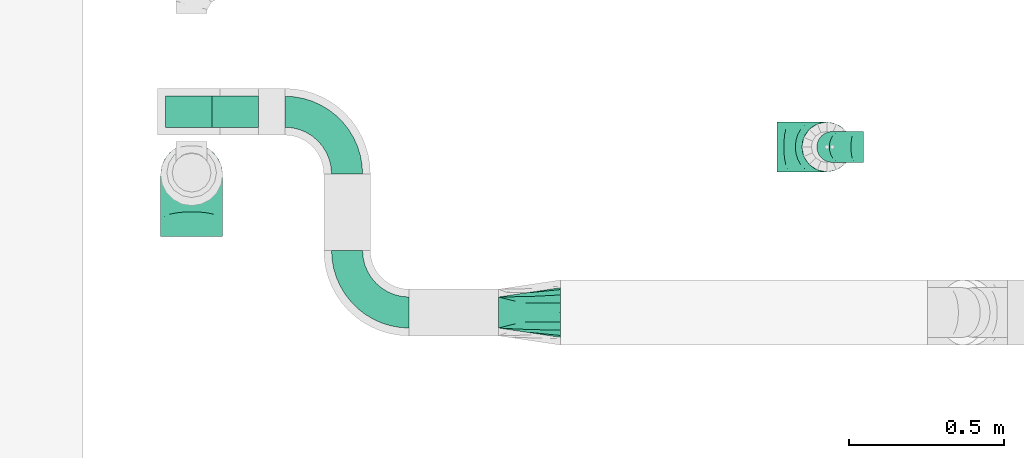
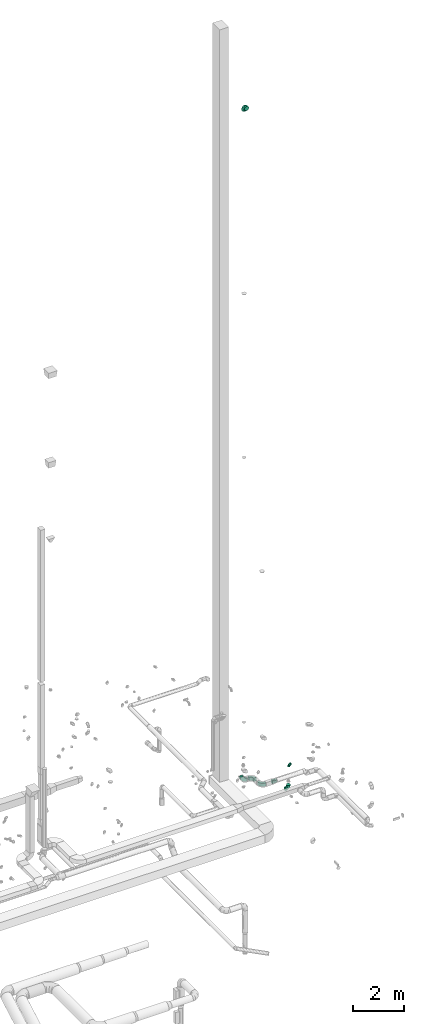
# One storey, part 74 of 97: 7 flow fittings.
"""IFC2X3 building model written with IfcOpenShell, lengths in millimetres."""

import ifcopenshell
import ifcopenshell.guid

model = None  # the IFC model being written
_history = None  # IfcOwnerHistory: only IFC2X3 demands one
_inside = {}  # id of a spatial element -> (the spatial element, [elements in it])
_under = {}  # id of a project, library or spatial element -> (it, [spatial elements below it])
_declared = {}  # id of a project -> (the project, [libraries it declares])
_typed = {}  # id of a type object -> (the type object, [elements of that type])
_made_of = {}  # id of a material, layer set ... -> (it, [elements and type objects made of it])


def new_model(schema):
    """Start an empty IFC model of exactly this schema.

    Asked for "IFC4X3", IfcOpenShell would pick the latest addendum, in which some entities
    have other attributes; the version numbers below select the first issue.
    IFC2X3 requires an IfcOwnerHistory on every rooted entity: one is made here for all.
    """
    global model, _history
    if schema == "IFC4X3":
        model = ifcopenshell.file(schema_version=(4, 3, 0, 0))
    else:
        model = ifcopenshell.file(schema=schema)
    _inside.clear()
    _under.clear()
    _declared.clear()
    _typed.clear()
    _made_of.clear()
    _history = None
    if model.schema == "IFC2X3":
        org = make("IfcOrganization", Name="unknown")
        user = make(
            "IfcPersonAndOrganization",
            ThePerson=make("IfcPerson", FamilyName="unknown"),
            TheOrganization=org,
        )
        app = make(
            "IfcApplication",
            ApplicationDeveloper=org,
            Version="unknown",
            ApplicationFullName="unknown",
            ApplicationIdentifier="unknown",
        )
        _history = make(
            "IfcOwnerHistory",
            OwningUser=user,
            OwningApplication=app,
            ChangeAction="ADDED",
            CreationDate=0,
        )
    return model


def make(cls, **values):
    """One entity of the class cls with the attributes given. An attribute that is None is left unset."""
    return model.create_entity(
        cls, **{name: value for name, value in values.items() if value is not None}
    )


def entity(cls, *values):
    """Any entity or typed value of the class cls, its attributes in the order of the schema. None: left unset."""
    e = model.create_entity(cls)
    for i, value in enumerate(values):
        if value is not None:
            e[i] = value
    return e


def rooted(cls, **values):
    """An entity with a GlobalId (a new one), such as an element, a storey or a relation."""
    return make(cls, GlobalId=ifcopenshell.guid.new(), OwnerHistory=_history, **values)


def si_unit(unit_type, name, prefix=None):
    """IfcSIUnit, for example si_unit("LENGTHUNIT", "METRE", prefix="MILLI")."""
    return make("IfcSIUnit", UnitType=unit_type, Prefix=prefix, Name=name)


def converted_unit(unit_type, name, factor, base, dimensions=None, offset=None):
    """IfcConversionBasedUnit, such as the inch: factor (a typed value) times the base unit."""
    return make(
        "IfcConversionBasedUnit"
        if offset is None
        else "IfcConversionBasedUnitWithOffset",
        ConversionOffset=offset,
        Dimensions=None
        if dimensions is None
        else entity("IfcDimensionalExponents", *dimensions),
        UnitType=unit_type,
        Name=name,
        ConversionFactor=make(
            "IfcMeasureWithUnit", ValueComponent=factor, UnitComponent=base
        ),
    )


def derived_unit(unit_type, elements):
    """IfcDerivedUnit: a product of units, each with its exponent."""
    return make(
        "IfcDerivedUnit",
        Elements=[
            make("IfcDerivedUnitElement", Unit=unit, Exponent=power)
            for unit, power in elements
        ],
        UnitType=unit_type,
    )


def assignment(units):
    """IfcUnitAssignment: the units of a project."""
    return None if units is None else make("IfcUnitAssignment", Units=units)


def point(xyz):
    """IfcCartesianPoint."""
    return None if xyz is None else make("IfcCartesianPoint", Coordinates=xyz)


def direction(xyz):
    """IfcDirection."""
    return None if xyz is None else make("IfcDirection", DirectionRatios=xyz)


def frame(location, z_axis=None, x_axis=None):
    """IfcAxis2Placement3D, a coordinate frame: its origin and axes. An axis left out is left unset."""
    return make(
        "IfcAxis2Placement3D",
        Location=point(location),
        Axis=direction(z_axis),
        RefDirection=direction(x_axis),
    )


def frame_2d(location, x_axis=None):
    """IfcAxis2Placement2D, a coordinate frame in the plane: its origin and x axis."""
    return make(
        "IfcAxis2Placement2D", Location=point(location), RefDirection=direction(x_axis)
    )


def origin():
    """The frame at (0, 0, 0) with its axes left unset."""
    return frame((0.0, 0.0, 0.0))


def place(relative_to, where):
    """IfcLocalPlacement: puts the frame where relative to a parent placement (None: the world)."""
    return make(
        "IfcLocalPlacement", PlacementRelTo=relative_to, RelativePlacement=where
    )


def context(
    kind, dimensions, precision=None, world=None, true_north=None, identifier=None
):
    """IfcGeometricRepresentationContext, for example the 3D "Model" context."""
    return make(
        "IfcGeometricRepresentationContext",
        ContextIdentifier=identifier,
        ContextType=kind,
        CoordinateSpaceDimension=dimensions,
        Precision=precision,
        WorldCoordinateSystem=world,
        TrueNorth=true_north,
    )


def subcontext(parent, identifier, kind, view, scale=None):
    """IfcGeometricRepresentationSubContext, for example "Body" below "Model"."""
    return make(
        "IfcGeometricRepresentationSubContext",
        ContextIdentifier=identifier,
        ContextType=kind,
        ParentContext=parent,
        TargetScale=scale,
        TargetView=view,
    )


def project(units=None, contexts=None):
    """IfcProject with its units and contexts."""
    return rooted(
        "IfcProject",
        Name="project",
        RepresentationContexts=contexts,
        UnitsInContext=assignment(units),
    )


def spatial(cls, under=None, at=None, **own):
    """A site, building, storey or space (cls), placed at a placement, below another one or the project."""
    s = rooted(cls, ObjectPlacement=at, **own)
    if under is not None:
        _under.setdefault(under.id(), (under, []))[1].append(s)
    return s


def polyline(points):
    """IfcPolyline through the points."""
    return make("IfcPolyline", Points=[point(p) for p in points])


def circle_curve(where, radius):
    """IfcCircle in the frame where."""
    return make("IfcCircle", Position=where, Radius=radius)


def parameter(value):
    """IfcParameterValue: where a trimmed curve begins or ends, as a parameter of its basis curve."""
    return model.create_entity("IfcParameterValue", value)


def trimmed(basis, trim1, trim2, sense, master):
    """IfcTrimmedCurve: the piece of a basis curve between two trims."""
    return make(
        "IfcTrimmedCurve",
        BasisCurve=basis,
        Trim1=trim1,
        Trim2=trim2,
        SenseAgreement=sense,
        MasterRepresentation=master,
    )


def segment(curve, same_sense, transition):
    """IfcCompositeCurveSegment."""
    return make(
        "IfcCompositeCurveSegment",
        Transition=transition,
        SameSense=same_sense,
        ParentCurve=curve,
    )


def composite_curve(segments, self_intersect=None):
    """IfcCompositeCurve: segments joined end to end."""
    return make("IfcCompositeCurve", Segments=segments, SelfIntersect=self_intersect)


def outline(outer, holes=None, kind="AREA"):
    """IfcArbitraryClosedProfileDef: a profile drawn as a closed curve; with holes, ...WithVoids."""
    if holes is None:
        return make("IfcArbitraryClosedProfileDef", ProfileType=kind, OuterCurve=outer)
    return make(
        "IfcArbitraryProfileDefWithVoids",
        ProfileType=kind,
        OuterCurve=outer,
        InnerCurves=holes,
    )


def extrude(swept, where, along, depth):
    """IfcExtrudedAreaSolid: the profile swept, set in the frame where, extruded along a direction by depth."""
    return make(
        "IfcExtrudedAreaSolid",
        SweptArea=swept,
        Position=where,
        ExtrudedDirection=direction(along),
        Depth=depth,
    )


def faces_of(points, faces, orient=None, outer=None):
    """IfcFace entities. A face is a list of loops; a loop is a list of indices into points, from 0.

    orient and outer hold one flag for each loop. By default every Orientation is true, the
    first loop of a face is its IfcFaceOuterBound and the others are IfcFaceBound.
    """
    made = []
    for i, loops in enumerate(faces):
        bounds = []
        for j, loop in enumerate(loops):
            is_outer = j == 0 if outer is None else outer[i][j]
            bounds.append(
                make(
                    "IfcFaceOuterBound" if is_outer else "IfcFaceBound",
                    Bound=make("IfcPolyLoop", Polygon=[points[k] for k in loop]),
                    Orientation=True if orient is None else orient[i][j],
                )
            )
        made.append(make("IfcFace", Bounds=bounds))
    return made


def faceted_brep(points, faces, orient=None, outer=None, voids=None):
    """IfcFacetedBrep: a solid bounded by flat faces; with voids (closed shells), ...WithVoids."""
    shared = [point(p) for p in points]
    hull = make("IfcClosedShell", CfsFaces=faces_of(shared, faces, orient, outer))
    if voids is None:
        return make("IfcFacetedBrep", Outer=hull)
    return make(
        "IfcFacetedBrepWithVoids",
        Outer=hull,
        Voids=[
            make(cls, CfsFaces=faces_of(shared, fs, o, b)) for cls, fs, o, b in voids
        ],
    )


def shape(context_of_items, identifier, shape_type, items):
    """IfcShapeRepresentation: the items that make up one representation, for example the "Body"."""
    return make(
        "IfcShapeRepresentation",
        ContextOfItems=context_of_items,
        RepresentationIdentifier=identifier,
        RepresentationType=shape_type,
        Items=items,
    )


def source(mapping_origin, context_of_items, identifier, shape_type, items):
    """IfcRepresentationMap: a shape defined once, which mapped items show again and again."""
    return make(
        "IfcRepresentationMap",
        MappingOrigin=mapping_origin,
        MappedRepresentation=shape(context_of_items, identifier, shape_type, items),
    )


def transform(
    local_origin,
    x_axis=None,
    y_axis=None,
    z_axis=None,
    scale=None,
    scale2=None,
    scale3=None,
    uniform=True,
):
    """IfcCartesianTransformationOperator3D, or its non-uniform kind. x_axis, y_axis, z_axis: its Axis1, 2, 3."""
    if uniform:
        return make(
            "IfcCartesianTransformationOperator3D",
            Axis1=direction(x_axis),
            Axis2=direction(y_axis),
            LocalOrigin=point(local_origin),
            Scale=scale,
            Axis3=direction(z_axis),
        )
    return make(
        "IfcCartesianTransformationOperator3DnonUniform",
        Axis1=direction(x_axis),
        Axis2=direction(y_axis),
        LocalOrigin=point(local_origin),
        Scale=scale,
        Axis3=direction(z_axis),
        Scale2=scale2,
        Scale3=scale3,
    )


def mapped(mapping_source, mapping_target):
    """IfcMappedItem: shows the shape of a source again, moved by a transform."""
    return make(
        "IfcMappedItem", MappingSource=mapping_source, MappingTarget=mapping_target
    )


def material(Name=None, Category=None):
    """IfcMaterial."""
    return make("IfcMaterial", Name=Name, Category=Category)


def made_of(thing, what):
    """Note that an element or type object is made of a material, layer set ...; save() writes the relation."""
    if what is not None:
        _made_of.setdefault(what.id(), (what, []))[1].append(thing)
    return thing


def type_object(cls, material=None, **own):
    """A type object (cls), such as IfcWallType, which elements share."""
    return made_of(rooted(cls, **own), material)


def type_shapes(of_type, sources):
    """Give a type object the sources (RepresentationMaps) that its elements show as mapped items."""
    of_type.RepresentationMaps = sources


def element(
    cls,
    number,
    at=None,
    inside=None,
    cuts=None,
    type_object=None,
    material=None,
    context=None,
    identifier="Body",
    shape_type=None,
    held_by="IfcProductDefinitionShape",
    body=None,
    shapes=None,
    **own,
):
    """One element of the class cls, such as IfcWall. Its Tag is "e" and its number.

    at: its placement. inside: the storey or other place that contains it. cuts: it is an
    opening in that element (IfcRelVoidsElement). A single representation is given by context,
    identifier, shape_type and body (its items); several are given by shapes. held_by: the class
    of the entity that holds the representations. save() writes the other relations.
    """
    e = rooted(cls, Tag="e%d" % number, ObjectPlacement=at, **own)
    if body is not None:
        shapes = [shape(context, identifier, shape_type, body)]
    if shapes is not None:
        e.Representation = make(held_by, Representations=shapes)
    if inside is not None:
        _inside.setdefault(inside.id(), (inside, []))[1].append(e)
    if cuts is not None:
        rooted(
            "IfcRelVoidsElement", RelatingBuildingElement=cuts, RelatedOpeningElement=e
        )
    if type_object is not None:
        _typed.setdefault(type_object.id(), (type_object, []))[1].append(e)
    return made_of(e, material)


def aggregate(whole, parts):
    """IfcRelAggregates: a whole, such as a stair, and the parts it consists of."""
    return rooted("IfcRelAggregates", RelatingObject=whole, RelatedObjects=parts)


def save(model, path):
    """Write the relations noted so far, then the file.

    IfcRelAggregates (storeys below a building ...), IfcRelContainedInSpatialStructure (elements
    in a storey), IfcRelDefinesByType, IfcRelAssociatesMaterial and IfcRelDeclares: one each for
    every whole, place, type object, material and project.
    """
    for whole, parts in _under.values():
        aggregate(whole, parts)
    for where, things in _inside.values():
        rooted(
            "IfcRelContainedInSpatialStructure",
            RelatedElements=things,
            RelatingStructure=where,
        )
    for kind, things in _typed.values():
        rooted("IfcRelDefinesByType", RelatedObjects=things, RelatingType=kind)
    for what, things in _made_of.values():
        rooted("IfcRelAssociatesMaterial", RelatedObjects=things, RelatingMaterial=what)
    for by, libraries in _declared.values():
        rooted("IfcRelDeclares", RelatingContext=by, RelatedDefinitions=libraries)
    model.write(path)


model = new_model("IFC2X3")

# Units and contexts
model_context = context("Model", 3, precision=0.01, world=origin(), true_north=direction((6.12303176911189e-17, 1.0)))
body_context = subcontext(model_context, "Body", "Model", "MODEL_VIEW")
ifc_project = project(units=[si_unit("LENGTHUNIT", "METRE", prefix="MILLI"), si_unit("AREAUNIT", "SQUARE_METRE"), si_unit("VOLUMEUNIT", "CUBIC_METRE"), converted_unit("PLANEANGLEUNIT", "DEGREE", entity("IfcRatioMeasure", 0.0174532925199433), si_unit("PLANEANGLEUNIT", "RADIAN"), dimensions=[0, 0, 0, 0, 0, 0, 0]), si_unit("MASSUNIT", "GRAM", prefix="KILO"), derived_unit("MASSDENSITYUNIT", [(si_unit("MASSUNIT", "GRAM", prefix="KILO"), 1), (si_unit("LENGTHUNIT", "METRE"), -3)]), derived_unit("MOMENTOFINERTIAUNIT", [(si_unit("LENGTHUNIT", "METRE"), 4)]), si_unit("TIMEUNIT", "SECOND"), si_unit("FREQUENCYUNIT", "HERTZ"), si_unit("THERMODYNAMICTEMPERATUREUNIT", "DEGREE_CELSIUS"), derived_unit("THERMALTRANSMITTANCEUNIT", [(si_unit("MASSUNIT", "GRAM", prefix="KILO"), 1), (si_unit("THERMODYNAMICTEMPERATUREUNIT", "KELVIN"), -1), (si_unit("TIMEUNIT", "SECOND"), -3)]), derived_unit("VOLUMETRICFLOWRATEUNIT", [(si_unit("LENGTHUNIT", "METRE"), 3), (si_unit("TIMEUNIT", "SECOND"), -1)]), derived_unit("MASSFLOWRATEUNIT", [(si_unit("MASSUNIT", "GRAM", prefix="KILO"), 1), (si_unit("TIMEUNIT", "SECOND"), -1)]), derived_unit("ROTATIONALFREQUENCYUNIT", [(si_unit("TIMEUNIT", "SECOND"), -1)]), si_unit("ELECTRICCURRENTUNIT", "AMPERE"), si_unit("ELECTRICVOLTAGEUNIT", "VOLT"), si_unit("POWERUNIT", "WATT"), si_unit("FORCEUNIT", "NEWTON", prefix="KILO"), si_unit("ILLUMINANCEUNIT", "LUX"), si_unit("LUMINOUSFLUXUNIT", "LUMEN"), si_unit("LUMINOUSINTENSITYUNIT", "CANDELA"), derived_unit("USERDEFINED", [(si_unit("MASSUNIT", "GRAM", prefix="KILO"), -1), (si_unit("LENGTHUNIT", "METRE"), -2), (si_unit("TIMEUNIT", "SECOND"), 3), (si_unit("LUMINOUSFLUXUNIT", "LUMEN"), 1)]), derived_unit("LINEARVELOCITYUNIT", [(si_unit("LENGTHUNIT", "METRE"), 1), (si_unit("TIMEUNIT", "SECOND"), -1)]), si_unit("PRESSUREUNIT", "PASCAL"), derived_unit("USERDEFINED", [(si_unit("LENGTHUNIT", "METRE"), -2), (si_unit("MASSUNIT", "GRAM", prefix="KILO"), 1), (si_unit("TIMEUNIT", "SECOND"), -2)]), derived_unit("LINEARFORCEUNIT", [(si_unit("MASSUNIT", "GRAM", prefix="KILO"), 1), (si_unit("LENGTHUNIT", "METRE"), 1), (si_unit("TIMEUNIT", "SECOND"), -2), (si_unit("LENGTHUNIT", "METRE"), -1)]), derived_unit("PLANARFORCEUNIT", [(si_unit("MASSUNIT", "GRAM", prefix="KILO"), 1), (si_unit("LENGTHUNIT", "METRE"), 1), (si_unit("TIMEUNIT", "SECOND"), -2), (si_unit("LENGTHUNIT", "METRE"), -2)])], contexts=[model_context])

# Site, building, storey
site_placement = place(None, origin())
site = spatial("IfcSite", under=ifc_project, at=site_placement, CompositionType="ELEMENT")
building_placement = place(site_placement, origin())
building = spatial("IfcBuilding", under=site, at=building_placement, CompositionType="ELEMENT")
storey_placement = place(building_placement, frame((0.0, 0.0, -4900.0)))
storey = spatial("IfcBuildingStorey", under=building, at=storey_placement, CompositionType="ELEMENT", Elevation=-4900.0)

# Flow fittings
ifc_material = material()
duct_fitting_type_1 = type_object("IfcDuctFittingType", PredefinedType="NOTDEFINED", material=ifc_material)
shared_shape_1 = source(origin(), body_context, "Body", "Brep", [
    faceted_brep([(-160.0, 0.0, -80.0), (-160.0, -20.71, -77.27), (-160.0, -40.0, -69.28), (-160.0, -56.57, -56.57), (-160.0, -69.28, -40.0), (-160.0, -77.27, -20.71), (-160.0, -80.0, 0.0), (-160.0, -77.27, 20.71), (-160.0, -69.28, 40.0), (-160.0, -56.57, 56.57), (-160.0, -40.0, 69.28), (-160.0, -20.71, 77.27), (-160.0, 0.0, 80.0), (-160.0, 20.71, 77.27), (-160.0, 40.0, 69.28), (-160.0, 56.57, 56.57), (-160.0, 69.28, 40.0), (-160.0, 77.27, 20.71), (-160.0, 80.0, 0.0), (-160.0, 77.27, -20.71), (-160.0, 69.28, -40.0), (-160.0, 56.57, -56.57), (-160.0, 40.0, -69.28), (-160.0, 20.71, -77.27), (-122.68, 20.71, 77.27), (-127.85, 40.0, 69.28), (-117.13, 0.0, 80.0), (-132.29, 56.57, 56.57), (-137.83, 77.27, 20.71), (-138.56, 80.0, 0.0), (-135.69, 69.28, 40.0), (-135.69, 69.28, -40.0), (-132.29, 56.57, -56.57), (-137.83, 77.27, -20.71), (-122.68, 20.71, -77.27), (-117.13, 0.0, -80.0), (-127.85, 40.0, -69.28), (-111.58, -20.71, -77.27), (-106.41, -40.0, -69.28), (-101.97, -56.57, -56.57), (-98.56, -69.28, -40.0), (-96.42, -77.27, -20.71), (-95.69, -80.0, 0.0), (-96.42, -77.27, 20.71), (-98.56, -69.28, 40.0), (-101.97, -56.57, 56.57), (-106.41, -40.0, 69.28), (-111.58, -20.71, 77.27), (-58.03, 58.03, 77.27), (-72.15, 72.15, 69.28), (-42.87, 42.87, 80.0), (-84.28, 84.28, 56.57), (-93.59, 93.59, 40.0), (-99.44, 99.44, 20.71), (-101.44, 101.44, 0.0), (-99.44, 99.44, -20.71), (-93.59, 93.59, -40.0), (-84.28, 84.28, -56.57), (-58.03, 58.03, -77.27), (-42.87, 42.87, -80.0), (-72.15, 72.15, -69.28), (-27.71, 27.71, -77.27), (-13.59, 13.59, -69.28), (-1.46, 1.46, -56.57), (7.85, -7.85, -40.0), (13.7, -13.7, -20.71), (15.69, -15.69, 0.0), (13.7, -13.7, 20.71), (7.85, -7.85, 40.0), (-1.46, 1.46, 56.57), (-13.59, 13.59, 69.28), (-27.71, 27.71, 77.27), (-20.71, 122.68, 77.27), (-40.0, 127.85, 69.28), (0.0, 117.13, 80.0), (-56.57, 132.29, 56.57), (-69.28, 135.69, 40.0), (-77.27, 137.83, 20.71), (-80.0, 138.56, 0.0), (-77.27, 137.83, -20.71), (-69.28, 135.69, -40.0), (-56.57, 132.29, -56.57), (-20.71, 122.68, -77.27), (0.0, 117.13, -80.0), (-40.0, 127.85, -69.28), (20.71, 111.58, -77.27), (40.0, 106.41, -69.28), (56.57, 101.97, -56.57), (69.28, 98.56, -40.0), (77.27, 96.42, -20.71), (80.0, 95.69, 0.0), (77.27, 96.42, 20.71), (69.28, 98.56, 40.0), (56.57, 101.97, 56.57), (40.0, 106.41, 69.28), (20.71, 111.58, 77.27), (-20.71, 160.0, -77.27), (-40.0, 160.0, -69.28), (-56.57, 160.0, -56.57), (-69.28, 160.0, -40.0), (-77.27, 160.0, -20.71), (-80.0, 160.0, 0.0), (-77.27, 160.0, 20.71), (-69.28, 160.0, 40.0), (-56.57, 160.0, 56.57), (-40.0, 160.0, 69.28), (-20.71, 160.0, 77.27), (0.0, 160.0, 80.0), (20.71, 160.0, 77.27), (40.0, 160.0, 69.28), (56.57, 160.0, 56.57), (69.28, 160.0, 40.0), (77.27, 160.0, 20.71), (80.0, 160.0, 0.0), (77.27, 160.0, -20.71), (69.28, 160.0, -40.0), (56.57, 160.0, -56.57), (40.0, 160.0, -69.28), (20.71, 160.0, -77.27), (0.0, 160.0, -80.0)], [[[0, 1, 2, 3, 4, 5, 6, 7, 8, 9, 10, 11, 12, 13, 14, 15, 16, 17, 18, 19, 20, 21, 22, 23]], [[24, 25, 14, 13]], [[26, 24, 13, 12]], [[14, 25, 27, 15]], [[28, 29, 18, 17]], [[30, 28, 17, 16]], [[15, 27, 30, 16]], [[20, 31, 32, 21]], [[33, 31, 20, 19]], [[18, 29, 33, 19]], [[34, 35, 0, 23]], [[36, 34, 23, 22]], [[32, 36, 22, 21]], [[1, 0, 35, 37]], [[2, 1, 37, 38]], [[3, 2, 38, 39]], [[5, 4, 40, 41]], [[6, 5, 41, 42]], [[39, 40, 4, 3]], [[6, 42, 43, 7]], [[7, 43, 44, 8]], [[8, 44, 45, 9]], [[9, 45, 46, 10]], [[10, 46, 47, 11]], [[26, 12, 11, 47]], [[48, 49, 25, 24]], [[50, 48, 24, 26]], [[27, 25, 49, 51]], [[52, 53, 28, 30]], [[51, 52, 30, 27]], [[29, 28, 53, 54]], [[55, 56, 31, 33]], [[54, 55, 33, 29]], [[32, 31, 56, 57]], [[58, 59, 35, 34]], [[60, 58, 34, 36]], [[57, 60, 36, 32]], [[37, 35, 59, 61]], [[38, 37, 61, 62]], [[39, 38, 62, 63]], [[41, 40, 64, 65]], [[42, 41, 65, 66]], [[63, 64, 40, 39]], [[43, 42, 66, 67]], [[44, 43, 67, 68]], [[68, 69, 45, 44]], [[46, 45, 69, 70]], [[47, 46, 70, 71]], [[26, 47, 71, 50]], [[72, 73, 49, 48]], [[74, 72, 48, 50]], [[51, 49, 73, 75]], [[76, 77, 53, 52]], [[75, 76, 52, 51]], [[54, 53, 77, 78]], [[79, 80, 56, 55]], [[78, 79, 55, 54]], [[57, 56, 80, 81]], [[82, 83, 59, 58]], [[84, 82, 58, 60]], [[81, 84, 60, 57]], [[61, 59, 83, 85]], [[62, 61, 85, 86]], [[63, 62, 86, 87]], [[65, 64, 88, 89]], [[66, 65, 89, 90]], [[87, 88, 64, 63]], [[67, 66, 90, 91]], [[68, 67, 91, 92]], [[92, 93, 69, 68]], [[70, 69, 93, 94]], [[71, 70, 94, 95]], [[50, 71, 95, 74]], [[96, 97, 98, 99, 100, 101, 102, 103, 104, 105, 106, 107, 108, 109, 110, 111, 112, 113, 114, 115, 116, 117, 118, 119]], [[72, 74, 107, 106]], [[73, 72, 106, 105]], [[75, 73, 105, 104]], [[77, 76, 103, 102]], [[78, 77, 102, 101]], [[75, 104, 103, 76]], [[78, 101, 100, 79]], [[79, 100, 99, 80]], [[80, 99, 98, 81]], [[84, 97, 96, 82]], [[82, 96, 119, 83]], [[84, 81, 98, 97]], [[118, 117, 86, 85]], [[119, 118, 85, 83]], [[116, 87, 86, 117]], [[88, 115, 114, 89]], [[89, 114, 113, 90]], [[115, 88, 87, 116]], [[112, 111, 92, 91]], [[113, 112, 91, 90]], [[111, 110, 93, 92]], [[95, 94, 109, 108]], [[74, 95, 108, 107]], [[110, 109, 94, 93]]]),
])
type_shapes(duct_fitting_type_1, [shared_shape_1])
flow_fitting_1_placement = place(storey_placement, frame((70659.02, 11756.74, 3247.0), z_axis=(0.0, 1.0, 0.0), x_axis=(0.0, 0.0, -1.0)))
element("IfcFlowFitting", 1, at=flow_fitting_1_placement, inside=storey, type_object=duct_fitting_type_1, material=ifc_material, context=body_context, shape_type="MappedRepresentation", body=[
    mapped(shared_shape_1, transform((0.0, 0.0, 0.0), scale=1.0)),
])
duct_fitting_type_2 = type_object("IfcDuctFittingType", PredefinedType="NOTDEFINED", material=ifc_material)
shared_shape_2 = source(origin(), body_context, "Body", "Brep", [
    faceted_brep([(-100.0, 0.0, -50.0), (-100.0, -12.94, -48.3), (-100.0, -25.0, -43.3), (-100.0, -35.36, -35.36), (-100.0, -43.3, -25.0), (-100.0, -48.3, -12.94), (-100.0, -50.0, 0.0), (-100.0, -48.3, 12.94), (-100.0, -43.3, 25.0), (-100.0, -35.36, 35.36), (-100.0, -25.0, 43.3), (-100.0, -12.94, 48.3), (-100.0, 0.0, 50.0), (-100.0, 12.94, 48.3), (-100.0, 25.0, 43.3), (-100.0, 35.36, 35.36), (-100.0, 43.3, 25.0), (-100.0, 48.3, 12.94), (-100.0, 50.0, 0.0), (-100.0, 48.3, -12.94), (-100.0, 43.3, -25.0), (-100.0, 35.36, -35.36), (-100.0, 25.0, -43.3), (-100.0, 12.94, -48.3), (-76.67, 12.94, 48.3), (-79.9, 25.0, 43.3), (-73.21, 0.0, 50.0), (-82.68, 35.36, 35.36), (-86.15, 48.3, 12.94), (-86.6, 50.0, 0.0), (-84.81, 43.3, 25.0), (-84.81, 43.3, -25.0), (-82.68, 35.36, -35.36), (-86.15, 48.3, -12.94), (-76.67, 12.94, -48.3), (-73.21, 0.0, -50.0), (-79.9, 25.0, -43.3), (-69.74, -12.94, -48.3), (-66.51, -25.0, -43.3), (-63.73, -35.36, -35.36), (-61.6, -43.3, -25.0), (-60.26, -48.3, -12.94), (-59.81, -50.0, 0.0), (-60.26, -48.3, 12.94), (-61.6, -43.3, 25.0), (-63.73, -35.36, 35.36), (-66.51, -25.0, 43.3), (-69.74, -12.94, 48.3), (-36.27, 36.27, 48.3), (-45.1, 45.1, 43.3), (-26.79, 26.79, 50.0), (-52.68, 52.68, 35.36), (-58.49, 58.49, 25.0), (-62.15, 62.15, 12.94), (-63.4, 63.4, 0.0), (-62.15, 62.15, -12.94), (-58.49, 58.49, -25.0), (-52.68, 52.68, -35.36), (-36.27, 36.27, -48.3), (-26.79, 26.79, -50.0), (-45.1, 45.1, -43.3), (-17.32, 17.32, -48.3), (-8.49, 8.49, -43.3), (-0.91, 0.91, -35.36), (4.9, -4.9, -25.0), (8.56, -8.56, -12.94), (9.81, -9.81, 0.0), (8.56, -8.56, 12.94), (4.9, -4.9, 25.0), (-0.91, 0.91, 35.36), (-8.49, 8.49, 43.3), (-17.32, 17.32, 48.3), (-12.94, 76.67, 48.3), (-25.0, 79.9, 43.3), (0.0, 73.21, 50.0), (-35.36, 82.68, 35.36), (-43.3, 84.81, 25.0), (-48.3, 86.15, 12.94), (-50.0, 86.6, 0.0), (-48.3, 86.15, -12.94), (-43.3, 84.81, -25.0), (-35.36, 82.68, -35.36), (-12.94, 76.67, -48.3), (0.0, 73.21, -50.0), (-25.0, 79.9, -43.3), (12.94, 69.74, -48.3), (25.0, 66.51, -43.3), (35.36, 63.73, -35.36), (43.3, 61.6, -25.0), (48.3, 60.26, -12.94), (50.0, 59.81, 0.0), (48.3, 60.26, 12.94), (43.3, 61.6, 25.0), (35.36, 63.73, 35.36), (25.0, 66.51, 43.3), (12.94, 69.74, 48.3), (-12.94, 100.0, -48.3), (-25.0, 100.0, -43.3), (-35.36, 100.0, -35.36), (-43.3, 100.0, -25.0), (-48.3, 100.0, -12.94), (-50.0, 100.0, 0.0), (-48.3, 100.0, 12.94), (-43.3, 100.0, 25.0), (-35.36, 100.0, 35.36), (-25.0, 100.0, 43.3), (-12.94, 100.0, 48.3), (0.0, 100.0, 50.0), (12.94, 100.0, 48.3), (25.0, 100.0, 43.3), (35.36, 100.0, 35.36), (43.3, 100.0, 25.0), (48.3, 100.0, 12.94), (50.0, 100.0, 0.0), (48.3, 100.0, -12.94), (43.3, 100.0, -25.0), (35.36, 100.0, -35.36), (25.0, 100.0, -43.3), (12.94, 100.0, -48.3), (0.0, 100.0, -50.0)], [[[0, 1, 2, 3, 4, 5, 6, 7, 8, 9, 10, 11, 12, 13, 14, 15, 16, 17, 18, 19, 20, 21, 22, 23]], [[24, 25, 14, 13]], [[26, 24, 13, 12]], [[14, 25, 27, 15]], [[28, 29, 18, 17]], [[30, 28, 17, 16]], [[15, 27, 30, 16]], [[20, 31, 32, 21]], [[33, 31, 20, 19]], [[18, 29, 33, 19]], [[34, 35, 0, 23]], [[36, 34, 23, 22]], [[32, 36, 22, 21]], [[2, 1, 37, 38]], [[3, 2, 38, 39]], [[0, 35, 37, 1]], [[5, 4, 40, 41]], [[6, 5, 41, 42]], [[3, 39, 40, 4]], [[6, 42, 43, 7]], [[7, 43, 44, 8]], [[8, 44, 45, 9]], [[10, 46, 47, 11]], [[11, 47, 26, 12]], [[10, 9, 45, 46]], [[48, 49, 25, 24]], [[50, 48, 24, 26]], [[27, 25, 49, 51]], [[52, 53, 28, 30]], [[51, 52, 30, 27]], [[29, 28, 53, 54]], [[55, 56, 31, 33]], [[54, 55, 33, 29]], [[57, 32, 31, 56]], [[58, 59, 35, 34]], [[60, 58, 34, 36]], [[57, 60, 36, 32]], [[37, 35, 59, 61]], [[38, 37, 61, 62]], [[39, 38, 62, 63]], [[41, 40, 64, 65]], [[42, 41, 65, 66]], [[63, 64, 40, 39]], [[43, 42, 66, 67]], [[44, 43, 67, 68]], [[68, 69, 45, 44]], [[46, 45, 69, 70]], [[47, 46, 70, 71]], [[26, 47, 71, 50]], [[72, 73, 49, 48]], [[74, 72, 48, 50]], [[51, 49, 73, 75]], [[76, 77, 53, 52]], [[75, 76, 52, 51]], [[54, 53, 77, 78]], [[79, 80, 56, 55]], [[78, 79, 55, 54]], [[81, 57, 56, 80]], [[82, 83, 59, 58]], [[84, 82, 58, 60]], [[81, 84, 60, 57]], [[61, 59, 83, 85]], [[62, 61, 85, 86]], [[63, 62, 86, 87]], [[65, 64, 88, 89]], [[66, 65, 89, 90]], [[87, 88, 64, 63]], [[67, 66, 90, 91]], [[68, 67, 91, 92]], [[92, 93, 69, 68]], [[70, 69, 93, 94]], [[71, 70, 94, 95]], [[50, 71, 95, 74]], [[96, 97, 98, 99, 100, 101, 102, 103, 104, 105, 106, 107, 108, 109, 110, 111, 112, 113, 114, 115, 116, 117, 118, 119]], [[72, 74, 107, 106]], [[73, 72, 106, 105]], [[75, 73, 105, 104]], [[77, 76, 103, 102]], [[78, 77, 102, 101]], [[75, 104, 103, 76]], [[78, 101, 100, 79]], [[79, 100, 99, 80]], [[80, 99, 98, 81]], [[96, 119, 83, 82]], [[97, 96, 82, 84]], [[84, 81, 98, 97]], [[83, 119, 118, 85]], [[85, 118, 117, 86]], [[86, 117, 116, 87]], [[88, 115, 114, 89]], [[89, 114, 113, 90]], [[87, 116, 115, 88]], [[91, 90, 113, 112]], [[92, 91, 112, 111]], [[93, 92, 111, 110]], [[95, 94, 109, 108]], [[74, 95, 108, 107]], [[110, 109, 94, 93]]]),
])
type_shapes(duct_fitting_type_2, [shared_shape_2])
flow_fitting_2_placement = place(storey_placement, frame((70676.87, 11756.74, 4350.0), z_axis=(1.88958848546712e-05, -1.0, 0.0), x_axis=(-1.0, -1.88958848546712e-05, 0.0)))
element("IfcFlowFitting", 2, at=flow_fitting_2_placement, inside=storey, type_object=duct_fitting_type_2, material=ifc_material, context=body_context, shape_type="MappedRepresentation", body=[
    mapped(shared_shape_2, transform((0.0, 0.0, 0.0), scale=1.0)),
])
duct_fitting_type_3 = type_object("IfcDuctFittingType", PredefinedType="NOTDEFINED", material=ifc_material)
shared_shape_3 = source(origin(), body_context, "Body", "Brep", [
    faceted_brep([(-200.0, 0.0, -100.0), (-200.0, -25.88, -96.59), (-200.0, -50.0, -86.6), (-200.0, -70.71, -70.71), (-200.0, -86.6, -50.0), (-200.0, -96.59, -25.88), (-200.0, -100.0, 0.0), (-200.0, -96.59, 25.88), (-200.0, -86.6, 50.0), (-200.0, -70.71, 70.71), (-200.0, -50.0, 86.6), (-200.0, -25.88, 96.59), (-200.0, 0.0, 100.0), (-200.0, 25.88, 96.59), (-200.0, 50.0, 86.6), (-200.0, 70.71, 70.71), (-200.0, 86.6, 50.0), (-200.0, 96.59, 25.88), (-200.0, 100.0, 0.0), (-200.0, 96.59, -25.88), (-200.0, 86.6, -50.0), (-200.0, 70.71, -70.71), (-200.0, 50.0, -86.6), (-200.0, 25.88, -96.59), (-153.35, 25.88, 96.59), (-159.81, 50.0, 86.6), (-146.41, 0.0, 100.0), (-165.36, 70.71, 70.71), (-172.29, 96.59, 25.88), (-173.21, 100.0, 0.0), (-169.62, 86.6, 50.0), (-169.62, 86.6, -50.0), (-165.36, 70.71, -70.71), (-172.29, 96.59, -25.88), (-153.35, 25.88, -96.59), (-146.41, 0.0, -100.0), (-159.81, 50.0, -86.6), (-139.48, -25.88, -96.59), (-133.01, -50.0, -86.6), (-127.46, -70.71, -70.71), (-123.21, -86.6, -50.0), (-120.53, -96.59, -25.88), (-119.62, -100.0, 0.0), (-120.53, -96.59, 25.88), (-123.21, -86.6, 50.0), (-127.46, -70.71, 70.71), (-133.01, -50.0, 86.6), (-139.48, -25.88, 96.59), (-72.54, 72.54, 96.59), (-90.19, 90.19, 86.6), (-53.59, 53.59, 100.0), (-105.35, 105.35, 70.71), (-116.99, 116.99, 50.0), (-124.3, 124.3, 25.88), (-126.79, 126.79, 0.0), (-124.3, 124.3, -25.88), (-116.99, 116.99, -50.0), (-105.35, 105.35, -70.71), (-72.54, 72.54, -96.59), (-53.59, 53.59, -100.0), (-90.19, 90.19, -86.6), (-34.64, 34.64, -96.59), (-16.99, 16.99, -86.6), (-1.83, 1.83, -70.71), (9.81, -9.81, -50.0), (17.12, -17.12, -25.88), (19.62, -19.62, 0.0), (17.12, -17.12, 25.88), (9.81, -9.81, 50.0), (-1.83, 1.83, 70.71), (-16.99, 16.99, 86.6), (-34.64, 34.64, 96.59), (-25.88, 153.35, 96.59), (-50.0, 159.81, 86.6), (0.0, 146.41, 100.0), (-70.71, 165.36, 70.71), (-86.6, 169.62, 50.0), (-96.59, 172.29, 25.88), (-100.0, 173.21, 0.0), (-96.59, 172.29, -25.88), (-86.6, 169.62, -50.0), (-70.71, 165.36, -70.71), (-25.88, 153.35, -96.59), (0.0, 146.41, -100.0), (-50.0, 159.81, -86.6), (25.88, 139.48, -96.59), (50.0, 133.01, -86.6), (70.71, 127.46, -70.71), (86.6, 123.21, -50.0), (96.59, 120.53, -25.88), (100.0, 119.62, 0.0), (96.59, 120.53, 25.88), (86.6, 123.21, 50.0), (70.71, 127.46, 70.71), (50.0, 133.01, 86.6), (25.88, 139.48, 96.59), (-25.88, 200.0, -96.59), (-50.0, 200.0, -86.6), (-70.71, 200.0, -70.71), (-86.6, 200.0, -50.0), (-96.59, 200.0, -25.88), (-100.0, 200.0, 0.0), (-96.59, 200.0, 25.88), (-86.6, 200.0, 50.0), (-70.71, 200.0, 70.71), (-50.0, 200.0, 86.6), (-25.88, 200.0, 96.59), (0.0, 200.0, 100.0), (25.88, 200.0, 96.59), (50.0, 200.0, 86.6), (70.71, 200.0, 70.71), (86.6, 200.0, 50.0), (96.59, 200.0, 25.88), (100.0, 200.0, 0.0), (96.59, 200.0, -25.88), (86.6, 200.0, -50.0), (70.71, 200.0, -70.71), (50.0, 200.0, -86.6), (25.88, 200.0, -96.59), (0.0, 200.0, -100.0)], [[[0, 1, 2, 3, 4, 5, 6, 7, 8, 9, 10, 11, 12, 13, 14, 15, 16, 17, 18, 19, 20, 21, 22, 23]], [[24, 25, 14, 13]], [[26, 24, 13, 12]], [[14, 25, 27, 15]], [[28, 29, 18, 17]], [[30, 28, 17, 16]], [[15, 27, 30, 16]], [[20, 31, 32, 21]], [[33, 31, 20, 19]], [[18, 29, 33, 19]], [[34, 35, 0, 23]], [[36, 34, 23, 22]], [[32, 36, 22, 21]], [[1, 0, 35, 37]], [[2, 1, 37, 38]], [[38, 39, 3, 2]], [[5, 4, 40, 41]], [[6, 5, 41, 42]], [[39, 40, 4, 3]], [[6, 42, 43, 7]], [[7, 43, 44, 8]], [[8, 44, 45, 9]], [[9, 45, 46, 10]], [[10, 46, 47, 11]], [[26, 12, 11, 47]], [[48, 49, 25, 24]], [[50, 48, 24, 26]], [[27, 25, 49, 51]], [[52, 53, 28, 30]], [[51, 52, 30, 27]], [[29, 28, 53, 54]], [[55, 56, 31, 33]], [[54, 55, 33, 29]], [[32, 31, 56, 57]], [[58, 59, 35, 34]], [[60, 58, 34, 36]], [[57, 60, 36, 32]], [[37, 35, 59, 61]], [[38, 37, 61, 62]], [[39, 38, 62, 63]], [[41, 40, 64, 65]], [[42, 41, 65, 66]], [[63, 64, 40, 39]], [[43, 42, 66, 67]], [[44, 43, 67, 68]], [[68, 69, 45, 44]], [[46, 45, 69, 70]], [[47, 46, 70, 71]], [[26, 47, 71, 50]], [[72, 73, 49, 48]], [[74, 72, 48, 50]], [[51, 49, 73, 75]], [[76, 77, 53, 52]], [[75, 76, 52, 51]], [[54, 53, 77, 78]], [[79, 80, 56, 55]], [[78, 79, 55, 54]], [[57, 56, 80, 81]], [[82, 83, 59, 58]], [[84, 82, 58, 60]], [[81, 84, 60, 57]], [[61, 59, 83, 85]], [[62, 61, 85, 86]], [[63, 62, 86, 87]], [[65, 64, 88, 89]], [[66, 65, 89, 90]], [[87, 88, 64, 63]], [[67, 66, 90, 91]], [[68, 67, 91, 92]], [[92, 93, 69, 68]], [[70, 69, 93, 94]], [[71, 70, 94, 95]], [[50, 71, 95, 74]], [[96, 97, 98, 99, 100, 101, 102, 103, 104, 105, 106, 107, 108, 109, 110, 111, 112, 113, 114, 115, 116, 117, 118, 119]], [[72, 74, 107, 106]], [[73, 72, 106, 105]], [[75, 73, 105, 104]], [[102, 101, 78, 77]], [[103, 102, 77, 76]], [[75, 104, 103, 76]], [[78, 101, 100, 79]], [[79, 100, 99, 80]], [[80, 99, 98, 81]], [[84, 97, 96, 82]], [[82, 96, 119, 83]], [[84, 81, 98, 97]], [[118, 117, 86, 85]], [[119, 118, 85, 83]], [[116, 87, 86, 117]], [[88, 115, 114, 89]], [[89, 114, 113, 90]], [[115, 88, 87, 116]], [[91, 90, 113, 112]], [[92, 91, 112, 111]], [[111, 110, 93, 92]], [[95, 94, 109, 108]], [[74, 95, 108, 107]], [[110, 109, 94, 93]]]),
])
type_shapes(duct_fitting_type_3, [shared_shape_3])
flow_fitting_3_placement = place(storey_placement, frame((68613.63, 11667.58, 36500.0), z_axis=(1.0, 0.0, 0.0), x_axis=(0.0, 0.0, 1.0)))
element("IfcFlowFitting", 3, at=flow_fitting_3_placement, inside=storey, type_object=duct_fitting_type_3, material=ifc_material, context=body_context, shape_type="MappedRepresentation", body=[
    mapped(shared_shape_3, transform((0.0, 0.0, 0.0), scale=1.0)),
])
duct_fitting_type_4 = type_object("IfcDuctFittingType", PredefinedType="NOTDEFINED", material=ifc_material)
shared_shape_4 = source(origin(), body_context, "Body", "Brep", [
    faceted_brep([(200.0, 30.61, 73.91), (200.0, 22.87, 75.45), (200.0, 15.12, 76.99), (200.0, 11.34, 77.74), (200.0, 7.56, 78.5), (200.0, 0.0, 80.0), (200.0, -7.56, 78.5), (200.0, -15.12, 76.99), (200.0, -18.99, 76.22), (200.0, -22.87, 75.45), (200.0, -30.61, 73.91), (200.0, -37.1, 69.57), (200.0, -43.59, 65.24), (200.0, -50.08, 60.9), (200.0, -56.57, 56.57), (200.0, -60.9, 50.08), (200.0, -65.24, 43.59), (200.0, -69.57, 37.1), (200.0, -73.91, 30.61), (200.0, -75.45, 22.87), (200.0, -76.99, 15.12), (200.0, -77.74, 11.34), (200.0, -78.5, 7.56), (200.0, -80.0, 0.0), (200.0, -78.5, -7.56), (200.0, -76.99, -15.12), (200.0, -76.22, -18.99), (200.0, -75.45, -22.87), (200.0, -73.91, -30.61), (200.0, -69.57, -37.1), (200.0, -65.24, -43.59), (200.0, -60.9, -50.08), (200.0, -56.57, -56.57), (200.0, -50.08, -60.9), (200.0, -43.59, -65.24), (200.0, -37.1, -69.57), (200.0, -30.61, -73.91), (200.0, -22.87, -75.45), (200.0, -15.12, -76.99), (200.0, -11.34, -77.74), (200.0, -7.56, -78.5), (200.0, 0.0, -80.0), (200.0, 7.56, -78.5), (200.0, 15.12, -76.99), (200.0, 18.99, -76.22), (200.0, 22.87, -75.45), (200.0, 30.61, -73.91), (200.0, 37.1, -69.57), (200.0, 43.59, -65.24), (200.0, 50.08, -60.9), (200.0, 56.57, -56.57), (200.0, 60.9, -50.08), (200.0, 65.24, -43.59), (200.0, 69.57, -37.1), (200.0, 73.91, -30.61), (200.0, 75.45, -22.87), (200.0, 76.99, -15.12), (200.0, 77.74, -11.34), (200.0, 78.5, -7.56), (200.0, 80.0, 0.0), (200.0, 78.5, 7.56), (200.0, 76.99, 15.12), (200.0, 76.22, 18.99), (200.0, 75.45, 22.87), (200.0, 73.91, 30.61), (200.0, 69.57, 37.1), (200.0, 65.24, 43.59), (200.0, 60.9, 50.08), (200.0, 56.57, 56.57), (200.0, 50.08, 60.9), (200.0, 43.59, 65.24), (200.0, 37.1, 69.57), (0.0, -50.0, 75.0), (0.0, 50.0, 75.0), (0.0, 50.0, -75.0), (0.0, -50.0, -75.0), (52.06, -36.99, 76.3), (78.09, -30.48, 76.95), (176.03, -5.99, 79.4), (152.06, -11.99, 78.8), (128.09, -17.98, 78.2), (104.11, -23.97, 77.6), (100.0, -54.94, 64.02), (78.09, -61.71, 45.72), (104.11, -65.62, 35.96), (128.09, -69.21, 26.97), (152.06, -72.81, 17.98), (164.04, -74.61, 13.48), (176.03, -76.4, 8.99), (26.03, -53.9, 65.24), (52.06, -57.81, 55.48), (26.03, -43.49, 75.65), (26.03, -53.9, -65.24), (52.06, -57.81, -55.48), (78.09, -61.71, -45.72), (104.11, -65.62, -35.96), (128.09, -69.21, -26.97), (152.06, -72.81, -17.98), (176.03, -76.4, -8.99), (100.0, -51.52, -67.44), (78.09, -30.48, -76.95), (104.11, -23.97, -77.6), (128.09, -17.98, -78.2), (152.06, -11.99, -78.8), (164.04, -8.99, -79.1), (176.03, -5.99, -79.4), (26.03, -43.49, -75.65), (52.06, -36.99, -76.3), (26.03, 43.49, -75.65), (52.06, 36.99, -76.3), (78.09, 30.48, -76.95), (104.11, 23.97, -77.6), (128.09, 17.98, -78.2), (152.06, 11.99, -78.8), (176.03, 5.99, -79.4), (100.0, 54.94, -64.02), (78.09, 61.71, -45.72), (104.11, 65.62, -35.96), (128.09, 69.21, -26.97), (152.06, 72.81, -17.98), (164.04, 74.61, -13.48), (176.03, 76.4, -8.99), (26.03, 53.9, -65.24), (52.06, 57.81, -55.48), (26.03, 53.9, 65.24), (52.06, 57.81, 55.48), (78.09, 61.71, 45.72), (104.11, 65.62, 35.96), (128.09, 69.21, 26.97), (152.06, 72.81, 17.98), (176.03, 76.4, 8.99), (100.0, 51.52, 67.44), (78.09, 30.48, 76.95), (104.11, 23.97, 77.6), (128.09, 17.98, 78.2), (152.06, 11.99, 78.8), (164.04, 8.99, 79.1), (176.03, 5.99, 79.4), (26.03, 43.49, 75.65), (52.06, 36.99, 76.3)], [[[0, 1, 2, 3, 4, 5, 6, 7, 8, 9, 10, 11, 12, 13, 14, 15, 16, 17, 18, 19, 20, 21, 22, 23, 24, 25, 26, 27, 28, 29, 30, 31, 32, 33, 34, 35, 36, 37, 38, 39, 40, 41, 42, 43, 44, 45, 46, 47, 48, 49, 50, 51, 52, 53, 54, 55, 56, 57, 58, 59, 60, 61, 62, 63, 64, 65, 66, 67, 68, 69, 70, 71]], [[72, 73, 74, 75]], [[76, 12, 77]], [[12, 11, 10, 77]], [[78, 79, 80, 81, 77, 10, 9, 8, 7, 6, 5]], [[13, 82, 14]], [[20, 19, 18, 83, 84, 85, 86, 87, 88, 23, 22, 21]], [[82, 72, 89]], [[82, 15, 14]], [[83, 16, 90]], [[91, 72, 82]], [[18, 17, 16, 83]], [[90, 16, 15]], [[15, 82, 89]], [[90, 15, 89]], [[76, 13, 12]], [[13, 76, 91]], [[82, 13, 91]], [[88, 87, 86, 85, 84, 83, 90, 89, 72, 75, 92, 93, 94, 95, 96, 97, 98, 23]], [[93, 30, 94]], [[30, 29, 28, 94]], [[98, 97, 96, 95, 94, 28, 27, 26, 25, 24, 23]], [[31, 99, 32]], [[38, 37, 36, 100, 101, 102, 103, 104, 105, 41, 40, 39]], [[99, 75, 106]], [[99, 33, 32]], [[100, 34, 107]], [[92, 75, 99]], [[36, 35, 34, 100]], [[107, 34, 33]], [[33, 99, 106]], [[107, 33, 106]], [[93, 31, 30]], [[31, 93, 92]], [[99, 31, 92]], [[105, 104, 103, 102, 101, 100, 107, 106, 75, 74, 108, 109, 110, 111, 112, 113, 114, 41]], [[109, 48, 110]], [[48, 47, 46, 110]], [[114, 113, 112, 111, 110, 46, 45, 44, 43, 42, 41]], [[49, 115, 50]], [[56, 55, 54, 116, 117, 118, 119, 120, 121, 59, 58, 57]], [[115, 74, 122]], [[115, 51, 50]], [[116, 52, 123]], [[108, 74, 115]], [[54, 53, 52, 116]], [[123, 52, 51]], [[51, 115, 122]], [[123, 51, 122]], [[109, 49, 48]], [[49, 109, 108]], [[115, 49, 108]], [[74, 73, 124, 125, 126, 127, 128, 129, 130, 59, 121, 120, 119, 118, 117, 116, 123, 122]], [[125, 66, 126]], [[66, 65, 64, 126]], [[130, 129, 128, 127, 126, 64, 63, 62, 61, 60, 59]], [[67, 131, 68]], [[2, 1, 0, 132, 133, 134, 135, 136, 137, 5, 4, 3]], [[131, 73, 138]], [[131, 69, 68]], [[132, 70, 139]], [[124, 73, 131]], [[0, 71, 70, 132]], [[139, 70, 69]], [[69, 131, 138]], [[139, 69, 138]], [[125, 67, 66]], [[67, 125, 124]], [[131, 67, 124]], [[73, 72, 91, 76, 77, 81, 80, 79, 78, 5, 137, 136, 135, 134, 133, 132, 139, 138]]]),
])
type_shapes(duct_fitting_type_4, [shared_shape_4])
flow_fitting_4_placement = place(storey_placement, frame((69601.87, 11223.58, 4225.0)))
element("IfcFlowFitting", 4, at=flow_fitting_4_placement, inside=storey, type_object=duct_fitting_type_4, material=ifc_material, context=body_context, shape_type="MappedRepresentation", body=[
    mapped(shared_shape_4, transform((0.0, 0.0, 0.0), scale=1.0)),
])
duct_fitting_type_5 = type_object("IfcDuctFittingType", PredefinedType="NOTDEFINED", material=ifc_material)
shared_shape_5 = source(origin(), body_context, "Body", "SweptSolid", [
    extrude(outline(composite_curve([segment(polyline([(-150.0, -100.0), (-50.0, -100.0)]), True, "CONTINUOUS"), segment(trimmed(circle_curve(frame_2d((100.0, -100.0), x_axis=(0.0, 1.0)), 150.0), [parameter(0.0)], [parameter(90.0000000000001)], True, "PARAMETER"), False, "CONTINUOUS"), segment(polyline([(100.0, 50.0), (100.0, 150.0)]), True, "CONTINUOUS"), segment(trimmed(circle_curve(frame_2d((100.0, -100.0), x_axis=(0.0, 1.0)), 250.0), [parameter(0.0)], [parameter(90.0000000000001)], True, "PARAMETER"), True, "CONTINUOUS")], self_intersect=False)), frame((-100.0, 100.0, -75.0), z_axis=(0.0, 0.0, 1.0), x_axis=(-1.0, 0.0, 0.0)), (0.0, 0.0, 1.0), 150.0),
])
type_shapes(duct_fitting_type_5, [shared_shape_5])
for number, where, z_axis, x_axis in (
    (5, (69114.1, 11870.03, 4225.0), (0.0, 0.0, 1.0), (0.0, 1.0, 0.0)),
    (6, (69114.1, 11223.58, 4225.0), (0.0, 0.0, 1.0), (0.0, -1.0, 0.0)),
):
    element("IfcFlowFitting", number, at=place(storey_placement, frame(where, z_axis=z_axis, x_axis=x_axis)), inside=storey, type_object=duct_fitting_type_5, material=ifc_material, context=body_context, shape_type="MappedRepresentation", body=[
        mapped(shared_shape_5, transform((0.0, 0.0, 0.0), scale=1.0)),
    ])
duct_fitting_type_6 = type_object("IfcDuctFittingType", PredefinedType="NOTDEFINED", material=ifc_material)
shared_shape_6 = source(origin(), body_context, "Body", "SweptSolid", [
    extrude(outline(composite_curve([segment(polyline([(-187.5, -112.5), (-37.5, -112.5)]), True, "CONTINUOUS"), segment(trimmed(circle_curve(frame_2d((112.5, -112.5), x_axis=(0.0, 1.0)), 150.0), [parameter(0.0)], [parameter(90.0000000000001)], True, "PARAMETER"), False, "CONTINUOUS"), segment(polyline([(112.5, 37.5), (112.5, 187.5)]), True, "CONTINUOUS"), segment(trimmed(circle_curve(frame_2d((112.5, -112.5), x_axis=(0.0, 1.0)), 300.0), [parameter(0.0)], [parameter(90.0000000000001)], True, "PARAMETER"), True, "CONTINUOUS")], self_intersect=False)), frame((-112.5, 112.5, -50.0), z_axis=(0.0, 0.0, 1.0), x_axis=(-1.0, 0.0, 0.0)), (0.0, 0.0, 1.0), 100.0),
])
type_shapes(duct_fitting_type_6, [shared_shape_6])
flow_fitting_5_placement = place(storey_placement, frame((68604.23, 11870.03, 4225.0), z_axis=(0.0, 1.0, 0.0), x_axis=(-1.0, 0.0, 0.0)))
element("IfcFlowFitting", 7, at=flow_fitting_5_placement, inside=storey, type_object=duct_fitting_type_6, material=ifc_material, context=body_context, shape_type="MappedRepresentation", body=[
    mapped(shared_shape_6, transform((0.0, 0.0, 0.0), scale=1.0)),
])

save(model, "model.ifc")
